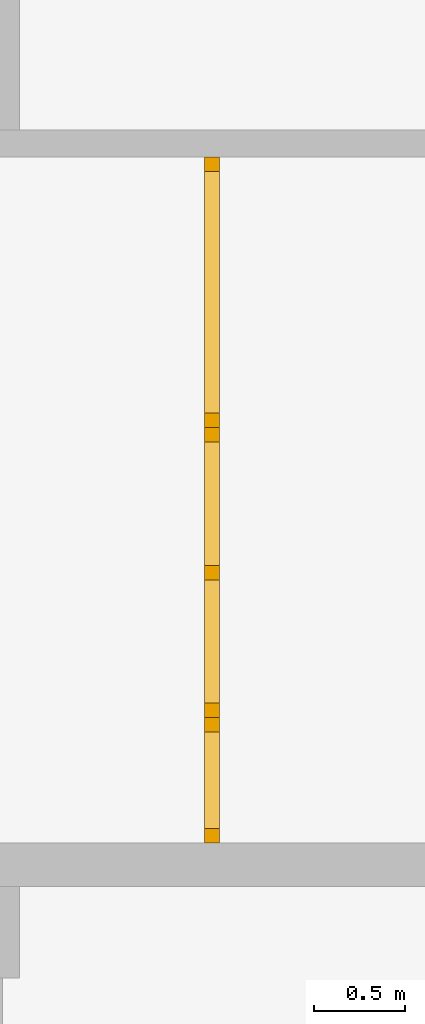
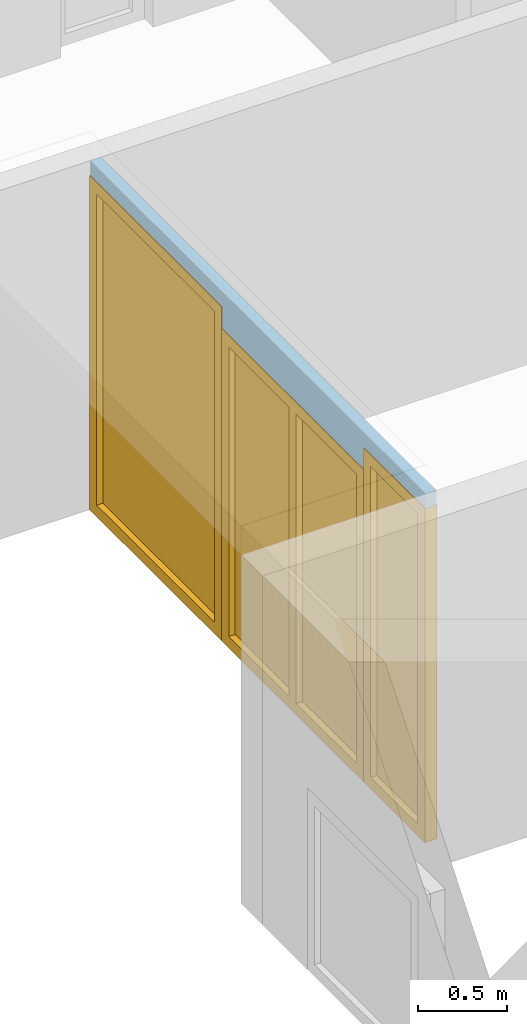
# One storey, part 5 of 8: 2 doors, 1 window, 3 openings, plus 1 element that does not belong to this part.
"""IFC2X3 building model written with IfcOpenShell, lengths in millimetres."""

from ifc_helpers import new_model, entity, si_unit, converted_unit, frame, frame_2d, origin, origin_with_axes, place, context, project, spatial, rectangle, extrude, faceted_brep, material, layer, layer_set, layer_usage, type_object, element, fill, save


model = new_model("IFC2X3")

# Units and contexts
model_context = context("Model", 3, precision=1e-05, world=origin())
plan_context = context("Plan", 3, precision=1e-05, world=origin())
ifc_project = project(units=[si_unit("LENGTHUNIT", "METRE", prefix="MILLI"), converted_unit("PLANEANGLEUNIT", "DEGREE", entity("IfcPlaneAngleMeasure", 0.0174532925199433), si_unit("PLANEANGLEUNIT", "RADIAN"), dimensions=[0, 0, 0, 0, 0, 0, 0]), si_unit("AREAUNIT", "SQUARE_METRE"), si_unit("VOLUMEUNIT", "CUBIC_METRE")], contexts=[model_context, plan_context])

# Building, storey
building_placement = place(None, origin())
building = spatial("IfcBuilding", under=ifc_project, at=building_placement, CompositionType="ELEMENT")
storey_placement = place(building_placement, frame((0.0, 0.0, 2900.0), z_axis=(0.0, 0.0, 1.0), x_axis=(1.0, 0.0, 0.0)))
storey = spatial("IfcBuildingStorey", under=building, at=storey_placement, Name="OG", CompositionType="ELEMENT", Elevation=2900.0)

# Wall, openings, doors, window
ifc_material_1 = material(Name="glas")
ifc_layer = layer(ifc_material_1, 70.0)
ifc_layer_set = layer_set([ifc_layer])
ifc_layer_usage = layer_usage(ifc_layer_set, "AXIS2", "POSITIVE", 0.0)
wall_placement = place(storey_placement, frame((22458.3517822139, 1928.4375, 0.0), z_axis=(0.0, 0.0, 1.0), x_axis=(0.0, 1.0, 0.0)))
wall = element("IfcWallStandardCase", 1, at=wall_placement, inside=storey, material=ifc_layer_usage, context=model_context, shape_type="SweptSolid", body=[
    extrude(rectangle(XDim=3780.0, YDim=70.0, at=frame_2d((1890.0, 35.0), x_axis=(1.0, 0.0))), origin_with_axes(), (0.0, 0.0, 1.0), 2400.0),
])
opening_1_placement = place(wall_placement, frame((2290.0, 0.0, 0.0), z_axis=(0.0, 1.0, 0.0), x_axis=(0.0, 0.0, 1.0)))
opening_1 = element("IfcOpeningElement", 2, at=opening_1_placement, cuts=wall, ObjectType="Opening", context=model_context, shape_type="SweptSolid", body=[
    extrude(rectangle(XDim=2300.0, YDim=1490.0, at=frame_2d((1150.0, 745.0), x_axis=(1.0, 0.0))), origin_with_axes(), (0.0, 0.0, 1.0), 70.0),
])
opening_2_placement = place(wall_placement, frame((0.0, 0.0, 0.0), z_axis=(0.0, 1.0, 0.0), x_axis=(0.0, 0.0, 1.0)))
opening_2 = element("IfcOpeningElement", 3, at=opening_2_placement, cuts=wall, ObjectType="Opening", context=model_context, shape_type="SweptSolid", body=[
    extrude(rectangle(XDim=2300.0, YDim=689.999999999996, at=frame_2d((1150.0, 344.999999999998), x_axis=(1.0, 0.0))), origin_with_axes(), (0.0, 0.0, 1.0), 70.0),
])
opening_3_placement = place(wall_placement, frame((689.999999999996, 0.0, 0.0), z_axis=(0.0, 1.0, 0.0), x_axis=(0.0, 0.0, 1.0)))
opening_3 = element("IfcOpeningElement", 4, at=opening_3_placement, cuts=wall, ObjectType="Opening", context=model_context, shape_type="SweptSolid", body=[
    extrude(rectangle(XDim=2150.0, YDim=1600.0, at=frame_2d((1075.0, 800.0), x_axis=(1.0, 0.0))), origin_with_axes(), (0.0, 0.0, 1.0), 70.0),
])
ifc_material_2 = material()
door_style_1 = type_object("IfcDoorStyle", Name="m", ConstructionType="NOTDEFINED", OperationType="USERDEFINED", ParameterTakesPrecedence=False, Sizeable=False)
door_1_placement = place(opening_1_placement, frame((0.0, 0.0, 0.0), z_axis=(1.0, 0.0, 0.0), x_axis=(0.0, 1.0, 0.0)))
door_1 = element("IfcDoor", 5, at=door_1_placement, inside=storey, type_object=door_style_1, material=ifc_material_2, Name="m", OverallHeight=2300.0, OverallWidth=1490.0, context=model_context, shape_type="Brep", body=[
    faceted_brep([(79.9999999999998, 75.0000000000016, 0.0), (79.9999999999998, 75.0000000000016, 2300.0), (-2.27373675443232e-13, 75.0000000000016, 2300.0), (-2.27373675443232e-13, 75.0000000000016, 0.0), (-2.27373675443232e-13, -4.99999999999845, 0.0), (-2.27373675443232e-13, -4.99999999999845, 2300.0), (79.9999999999998, -4.99999999999845, 2300.0), (79.9999999999998, -4.99999999999845, 0.0), (-2.27373675443232e-13, 75.0000000000016, 0.0), (-2.27373675443232e-13, -4.99999999999845, 0.0), (79.9999999999998, -4.99999999999845, 0.0), (79.9999999999998, 75.0000000000016, 0.0), (-2.27373675443232e-13, 75.0000000000016, 2300.0), (-2.27373675443232e-13, -4.99999999999845, 2300.0), (-2.27373675443232e-13, -4.99999999999845, 0.0), (-2.27373675443232e-13, 75.0000000000016, 0.0), (79.9999999999998, 75.0000000000016, 2300.0), (79.9999999999998, -4.99999999999845, 2300.0), (-2.27373675443232e-13, -4.99999999999845, 2300.0), (-2.27373675443232e-13, 75.0000000000016, 2300.0), (79.9999999999998, 75.0000000000016, 0.0), (79.9999999999998, -4.99999999999845, 0.0), (79.9999999999998, -4.99999999999845, 2300.0), (79.9999999999998, 75.0000000000016, 2300.0)], [[[0, 1, 2, 3]], [[4, 5, 6, 7]], [[8, 9, 10, 11]], [[12, 13, 14, 15]], [[16, 17, 18, 19]], [[20, 21, 22, 23]]], orient=[[False], [False], [False], [False], [False], [False]]),
    faceted_brep([(1410.0, 75.0000000000015, 2300.0), (1410.0, 75.0000000000015, 0.0), (1490.0, 75.0000000000015, 0.0), (1490.0, 75.0000000000015, 2300.0), (1490.0, -4.99999999999854, 2300.0), (1490.0, -4.99999999999854, 0.0), (1410.0, -4.99999999999854, 0.0), (1410.0, -4.99999999999854, 2300.0), (1490.0, 75.0000000000015, 2300.0), (1490.0, -4.99999999999854, 2300.0), (1410.0, -4.99999999999854, 2300.0), (1410.0, 75.0000000000015, 2300.0), (1490.0, 75.0000000000015, 0.0), (1490.0, -4.99999999999854, 0.0), (1490.0, -4.99999999999854, 2300.0), (1490.0, 75.0000000000015, 2300.0), (1410.0, 75.0000000000015, 0.0), (1410.0, -4.99999999999854, 0.0), (1490.0, -4.99999999999854, 0.0), (1490.0, 75.0000000000015, 0.0), (1410.0, 75.0000000000015, 2300.0), (1410.0, -4.99999999999854, 2300.0), (1410.0, -4.99999999999854, 0.0), (1410.0, 75.0000000000015, 0.0)], [[[0, 1, 2, 3]], [[4, 5, 6, 7]], [[8, 9, 10, 11]], [[12, 13, 14, 15]], [[16, 17, 18, 19]], [[20, 21, 22, 23]]], orient=[[False], [False], [False], [False], [False], [False]]),
    faceted_brep([(79.9999999999998, 75.0000000000015, 2220.0), (1410.0, 75.0000000000015, 2220.0), (1410.0, 75.0000000000015, 2300.0), (79.9999999999998, 75.0000000000015, 2300.0), (79.9999999999998, -4.99999999999847, 2300.0), (1410.0, -4.99999999999855, 2300.0), (1410.0, -4.99999999999855, 2220.0), (79.9999999999998, -4.99999999999847, 2220.0), (79.9999999999998, 75.0000000000015, 2300.0), (79.9999999999998, -4.99999999999847, 2300.0), (79.9999999999998, -4.99999999999847, 2220.0), (79.9999999999998, 75.0000000000015, 2220.0), (1410.0, 75.0000000000015, 2300.0), (1410.0, -4.99999999999855, 2300.0), (79.9999999999998, -4.99999999999847, 2300.0), (79.9999999999998, 75.0000000000015, 2300.0), (1410.0, 75.0000000000015, 2220.0), (1410.0, -4.99999999999855, 2220.0), (1410.0, -4.99999999999855, 2300.0), (1410.0, 75.0000000000015, 2300.0), (79.9999999999998, 75.0000000000015, 2220.0), (79.9999999999998, -4.99999999999847, 2220.0), (1410.0, -4.99999999999855, 2220.0), (1410.0, 75.0000000000015, 2220.0)], [[[0, 1, 2, 3]], [[4, 5, 6, 7]], [[8, 9, 10, 11]], [[12, 13, 14, 15]], [[16, 17, 18, 19]], [[20, 21, 22, 23]]], orient=[[False], [False], [False], [False], [False], [False]]),
    faceted_brep([(1410.0, 75.0000000000015, 80.0), (79.9999999999998, 75.0000000000015, 80.0), (79.9999999999998, 75.0000000000015, 0.0), (1410.0, 75.0000000000015, 0.0), (1410.0, -4.99999999999855, 0.0), (79.9999999999998, -4.99999999999847, 0.0), (79.9999999999998, -4.99999999999847, 80.0), (1410.0, -4.99999999999855, 80.0), (1410.0, 75.0000000000015, 0.0), (1410.0, -4.99999999999855, 0.0), (1410.0, -4.99999999999855, 80.0), (1410.0, 75.0000000000015, 80.0), (79.9999999999998, 75.0000000000015, 0.0), (79.9999999999998, -4.99999999999847, 0.0), (1410.0, -4.99999999999855, 0.0), (1410.0, 75.0000000000015, 0.0), (79.9999999999998, 75.0000000000015, 80.0), (79.9999999999998, -4.99999999999847, 80.0), (79.9999999999998, -4.99999999999847, 0.0), (79.9999999999998, 75.0000000000015, 0.0), (1410.0, 75.0000000000015, 80.0), (1410.0, -4.99999999999855, 80.0), (79.9999999999998, -4.99999999999847, 80.0), (79.9999999999998, 75.0000000000015, 80.0)], [[[0, 1, 2, 3]], [[4, 5, 6, 7]], [[8, 9, 10, 11]], [[12, 13, 14, 15]], [[16, 17, 18, 19]], [[20, 21, 22, 23]]], orient=[[False], [False], [False], [False], [False], [False]]),
    faceted_brep([(79.9999999999998, 35.0000000000015, 80.0), (1410.0, 35.0000000000015, 80.0), (1410.0, 35.0000000000015, 2220.0), (79.9999999999998, 35.0000000000015, 2220.0), (79.9999999999998, 34.0000000000015, 80.0), (79.9999999999998, 34.0000000000015, 2220.0), (1410.0, 34.0000000000015, 2220.0), (1410.0, 34.0000000000015, 80.0), (79.9999999999998, 35.0000000000015, 80.0), (79.9999999999998, 34.0000000000015, 80.0), (1410.0, 34.0000000000015, 80.0), (1410.0, 35.0000000000015, 80.0), (1410.0, 35.0000000000015, 80.0), (1410.0, 34.0000000000015, 80.0), (1410.0, 34.0000000000015, 2220.0), (1410.0, 35.0000000000015, 2220.0), (1410.0, 35.0000000000015, 2220.0), (1410.0, 34.0000000000015, 2220.0), (79.9999999999998, 34.0000000000015, 2220.0), (79.9999999999998, 35.0000000000015, 2220.0), (79.9999999999998, 35.0000000000015, 2220.0), (79.9999999999998, 34.0000000000015, 2220.0), (79.9999999999998, 34.0000000000015, 80.0), (79.9999999999998, 35.0000000000015, 80.0)], [[[0, 1, 2, 3]], [[4, 5, 6, 7]], [[8, 9, 10, 11]], [[12, 13, 14, 15]], [[16, 17, 18, 19]], [[20, 21, 22, 23]]], orient=[[False], [False], [False], [False], [False], [False]]),
])
fill(opening_1, door_1)
ifc_material_3 = material()
door_style_2 = type_object("IfcDoorStyle", Name="Verglasung 01", ConstructionType="NOTDEFINED", OperationType="USERDEFINED", ParameterTakesPrecedence=False, Sizeable=False)
door_2_placement = place(opening_2_placement, frame((0.0, 0.0, 0.0), z_axis=(1.0, 0.0, 0.0), x_axis=(0.0, 1.0, 0.0)))
door_2 = element("IfcDoor", 6, at=door_2_placement, inside=storey, type_object=door_style_2, material=ifc_material_3, Name="Verglasung 01", OverallHeight=2300.0, OverallWidth=690.0, context=model_context, shape_type="Brep", body=[
    faceted_brep([(80.0, 75.0000000000015, 0.0), (80.0, 75.0000000000015, 2300.0), (0.0, 75.0000000000015, 2300.0), (0.0, 75.0000000000015, 0.0), (0.0, -4.99999999999849, 0.0), (0.0, -4.99999999999849, 2300.0), (80.0, -4.99999999999849, 2300.0), (80.0, -4.99999999999849, 0.0), (0.0, 75.0000000000015, 0.0), (0.0, -4.99999999999849, 0.0), (80.0, -4.99999999999849, 0.0), (80.0, 75.0000000000015, 0.0), (0.0, 75.0000000000015, 2300.0), (0.0, -4.99999999999849, 2300.0), (0.0, -4.99999999999849, 0.0), (0.0, 75.0000000000015, 0.0), (80.0, 75.0000000000015, 2300.0), (80.0, -4.99999999999849, 2300.0), (0.0, -4.99999999999849, 2300.0), (0.0, 75.0000000000015, 2300.0), (80.0, 75.0000000000015, 0.0), (80.0, -4.99999999999849, 0.0), (80.0, -4.99999999999849, 2300.0), (80.0, 75.0000000000015, 2300.0)], [[[0, 1, 2, 3]], [[4, 5, 6, 7]], [[8, 9, 10, 11]], [[12, 13, 14, 15]], [[16, 17, 18, 19]], [[20, 21, 22, 23]]], orient=[[False], [False], [False], [False], [False], [False]]),
    faceted_brep([(609.999999999996, 75.0000000000015, 2300.0), (609.999999999996, 75.0000000000015, 0.0), (689.999999999996, 75.0000000000015, 0.0), (689.999999999996, 75.0000000000015, 2300.0), (689.999999999996, -4.99999999999854, 2300.0), (689.999999999996, -4.99999999999854, 0.0), (609.999999999996, -4.99999999999854, 0.0), (609.999999999996, -4.99999999999854, 2300.0), (689.999999999996, 75.0000000000015, 2300.0), (689.999999999996, -4.99999999999854, 2300.0), (609.999999999996, -4.99999999999854, 2300.0), (609.999999999996, 75.0000000000015, 2300.0), (689.999999999996, 75.0000000000015, 0.0), (689.999999999996, -4.99999999999854, 0.0), (689.999999999996, -4.99999999999854, 2300.0), (689.999999999996, 75.0000000000015, 2300.0), (609.999999999996, 75.0000000000015, 0.0), (609.999999999996, -4.99999999999854, 0.0), (689.999999999996, -4.99999999999854, 0.0), (689.999999999996, 75.0000000000015, 0.0), (609.999999999996, 75.0000000000015, 2300.0), (609.999999999996, -4.99999999999854, 2300.0), (609.999999999996, -4.99999999999854, 0.0), (609.999999999996, 75.0000000000015, 0.0)], [[[0, 1, 2, 3]], [[4, 5, 6, 7]], [[8, 9, 10, 11]], [[12, 13, 14, 15]], [[16, 17, 18, 19]], [[20, 21, 22, 23]]], orient=[[False], [False], [False], [False], [False], [False]]),
    faceted_brep([(80.0, 75.0000000000015, 2220.0), (609.999999999996, 75.0000000000015, 2220.0), (609.999999999996, 75.0000000000015, 2300.0), (80.0, 75.0000000000015, 2300.0), (80.0, -4.99999999999851, 2300.0), (609.999999999996, -4.99999999999855, 2300.0), (609.999999999996, -4.99999999999855, 2220.0), (80.0, -4.99999999999851, 2220.0), (80.0, 75.0000000000015, 2300.0), (80.0, -4.99999999999851, 2300.0), (80.0, -4.99999999999851, 2220.0), (80.0, 75.0000000000015, 2220.0), (609.999999999996, 75.0000000000015, 2300.0), (609.999999999996, -4.99999999999855, 2300.0), (80.0, -4.99999999999851, 2300.0), (80.0, 75.0000000000015, 2300.0), (609.999999999996, 75.0000000000015, 2220.0), (609.999999999996, -4.99999999999855, 2220.0), (609.999999999996, -4.99999999999855, 2300.0), (609.999999999996, 75.0000000000015, 2300.0), (80.0, 75.0000000000015, 2220.0), (80.0, -4.99999999999851, 2220.0), (609.999999999996, -4.99999999999855, 2220.0), (609.999999999996, 75.0000000000015, 2220.0)], [[[0, 1, 2, 3]], [[4, 5, 6, 7]], [[8, 9, 10, 11]], [[12, 13, 14, 15]], [[16, 17, 18, 19]], [[20, 21, 22, 23]]], orient=[[False], [False], [False], [False], [False], [False]]),
    faceted_brep([(609.999999999996, 75.0000000000015, 80.0), (80.0, 75.0000000000015, 80.0), (80.0, 75.0000000000015, 0.0), (609.999999999996, 75.0000000000015, 0.0), (609.999999999996, -4.99999999999855, 0.0), (80.0, -4.99999999999851, 0.0), (80.0, -4.99999999999851, 80.0), (609.999999999996, -4.99999999999855, 80.0), (609.999999999996, 75.0000000000015, 0.0), (609.999999999996, -4.99999999999855, 0.0), (609.999999999996, -4.99999999999855, 80.0), (609.999999999996, 75.0000000000015, 80.0), (80.0, 75.0000000000015, 0.0), (80.0, -4.99999999999851, 0.0), (609.999999999996, -4.99999999999855, 0.0), (609.999999999996, 75.0000000000015, 0.0), (80.0, 75.0000000000015, 80.0), (80.0, -4.99999999999851, 80.0), (80.0, -4.99999999999851, 0.0), (80.0, 75.0000000000015, 0.0), (609.999999999996, 75.0000000000015, 80.0), (609.999999999996, -4.99999999999855, 80.0), (80.0, -4.99999999999851, 80.0), (80.0, 75.0000000000015, 80.0)], [[[0, 1, 2, 3]], [[4, 5, 6, 7]], [[8, 9, 10, 11]], [[12, 13, 14, 15]], [[16, 17, 18, 19]], [[20, 21, 22, 23]]], orient=[[False], [False], [False], [False], [False], [False]]),
    faceted_brep([(80.0, 35.0000000000015, 80.0), (609.999999999996, 35.0000000000015, 80.0), (609.999999999996, 35.0000000000015, 2220.0), (80.0, 35.0000000000015, 2220.0), (80.0, 34.0000000000015, 80.0), (80.0, 34.0000000000015, 2220.0), (609.999999999996, 34.0000000000015, 2220.0), (609.999999999996, 34.0000000000015, 80.0), (80.0, 35.0000000000015, 80.0), (80.0, 34.0000000000015, 80.0), (609.999999999996, 34.0000000000015, 80.0), (609.999999999996, 35.0000000000015, 80.0), (609.999999999996, 35.0000000000015, 80.0), (609.999999999996, 34.0000000000015, 80.0), (609.999999999996, 34.0000000000015, 2220.0), (609.999999999996, 35.0000000000015, 2220.0), (609.999999999996, 35.0000000000015, 2220.0), (609.999999999996, 34.0000000000015, 2220.0), (80.0, 34.0000000000015, 2220.0), (80.0, 35.0000000000015, 2220.0), (80.0, 35.0000000000015, 2220.0), (80.0, 34.0000000000015, 2220.0), (80.0, 34.0000000000015, 80.0), (80.0, 35.0000000000015, 80.0)], [[[0, 1, 2, 3]], [[4, 5, 6, 7]], [[8, 9, 10, 11]], [[12, 13, 14, 15]], [[16, 17, 18, 19]], [[20, 21, 22, 23]]], orient=[[False], [False], [False], [False], [False], [False]]),
])
fill(opening_2, door_2)
ifc_material_4 = material()
window_placement = place(opening_3_placement, frame((0.0, 0.0, 0.0), z_axis=(1.0, 0.0, 0.0), x_axis=(0.0, 1.0, 0.0)))
window = element("IfcWindow", 7, at=window_placement, inside=storey, material=ifc_material_4, Name="m", OverallHeight=2150.0, OverallWidth=1600.0, context=model_context, shape_type="Brep", body=[
    faceted_brep([(80.0000000000005, 75.0000000000016, 0.0), (80.0000000000005, 75.0000000000016, 2150.0), (4.54747350886464e-13, 75.0000000000016, 2150.0), (4.54747350886464e-13, 75.0000000000016, 0.0), (4.54747350886464e-13, -4.99999999999844, 0.0), (4.54747350886464e-13, -4.99999999999844, 2150.0), (80.0000000000005, -4.99999999999844, 2150.0), (80.0000000000005, -4.99999999999844, 0.0), (4.54747350886464e-13, 75.0000000000016, 0.0), (4.54747350886464e-13, -4.99999999999844, 0.0), (80.0000000000005, -4.99999999999844, 0.0), (80.0000000000005, 75.0000000000016, 0.0), (4.54747350886464e-13, 75.0000000000016, 2150.0), (4.54747350886464e-13, -4.99999999999844, 2150.0), (4.54747350886464e-13, -4.99999999999844, 0.0), (4.54747350886464e-13, 75.0000000000016, 0.0), (80.0000000000005, 75.0000000000016, 2150.0), (80.0000000000005, -4.99999999999844, 2150.0), (4.54747350886464e-13, -4.99999999999844, 2150.0), (4.54747350886464e-13, 75.0000000000016, 2150.0), (80.0000000000005, 75.0000000000016, 0.0), (80.0000000000005, -4.99999999999844, 0.0), (80.0000000000005, -4.99999999999844, 2150.0), (80.0000000000005, 75.0000000000016, 2150.0)], [[[0, 1, 2, 3]], [[4, 5, 6, 7]], [[8, 9, 10, 11]], [[12, 13, 14, 15]], [[16, 17, 18, 19]], [[20, 21, 22, 23]]], orient=[[False], [False], [False], [False], [False], [False]]),
    faceted_brep([(1520.0, 75.0000000000015, 2150.0), (1520.0, 75.0000000000015, 0.0), (1600.0, 75.0000000000015, 0.0), (1600.0, 75.0000000000015, 2150.0), (1600.0, -4.99999999999854, 2150.0), (1600.0, -4.99999999999854, 0.0), (1520.0, -4.99999999999854, 0.0), (1520.0, -4.99999999999854, 2150.0), (1600.0, 75.0000000000015, 2150.0), (1600.0, -4.99999999999854, 2150.0), (1520.0, -4.99999999999854, 2150.0), (1520.0, 75.0000000000015, 2150.0), (1600.0, 75.0000000000015, 0.0), (1600.0, -4.99999999999854, 0.0), (1600.0, -4.99999999999854, 2150.0), (1600.0, 75.0000000000015, 2150.0), (1520.0, 75.0000000000015, 0.0), (1520.0, -4.99999999999854, 0.0), (1600.0, -4.99999999999854, 0.0), (1600.0, 75.0000000000015, 0.0), (1520.0, 75.0000000000015, 2150.0), (1520.0, -4.99999999999854, 2150.0), (1520.0, -4.99999999999854, 0.0), (1520.0, 75.0000000000015, 0.0)], [[[0, 1, 2, 3]], [[4, 5, 6, 7]], [[8, 9, 10, 11]], [[12, 13, 14, 15]], [[16, 17, 18, 19]], [[20, 21, 22, 23]]], orient=[[False], [False], [False], [False], [False], [False]]),
    faceted_brep([(80.0000000000005, 75.0000000000015, 2070.0), (1520.0, 75.0000000000015, 2070.0), (1520.0, 75.0000000000015, 2150.0), (80.0000000000005, 75.0000000000015, 2150.0), (80.0000000000005, -4.99999999999845, 2150.0), (1520.0, -4.99999999999855, 2150.0), (1520.0, -4.99999999999855, 2070.0), (80.0000000000005, -4.99999999999845, 2070.0), (80.0000000000005, 75.0000000000015, 2150.0), (80.0000000000005, -4.99999999999845, 2150.0), (80.0000000000005, -4.99999999999845, 2070.0), (80.0000000000005, 75.0000000000015, 2070.0), (1520.0, 75.0000000000015, 2150.0), (1520.0, -4.99999999999855, 2150.0), (80.0000000000005, -4.99999999999845, 2150.0), (80.0000000000005, 75.0000000000015, 2150.0), (1520.0, 75.0000000000015, 2070.0), (1520.0, -4.99999999999855, 2070.0), (1520.0, -4.99999999999855, 2150.0), (1520.0, 75.0000000000015, 2150.0), (80.0000000000005, 75.0000000000015, 2070.0), (80.0000000000005, -4.99999999999845, 2070.0), (1520.0, -4.99999999999855, 2070.0), (1520.0, 75.0000000000015, 2070.0)], [[[0, 1, 2, 3]], [[4, 5, 6, 7]], [[8, 9, 10, 11]], [[12, 13, 14, 15]], [[16, 17, 18, 19]], [[20, 21, 22, 23]]], orient=[[False], [False], [False], [False], [False], [False]]),
    faceted_brep([(1520.0, 75.0000000000015, 80.0), (80.0000000000005, 75.0000000000015, 80.0), (80.0000000000005, 75.0000000000015, 0.0), (1520.0, 75.0000000000015, 0.0), (1520.0, -4.99999999999855, 0.0), (80.0000000000005, -4.99999999999845, 0.0), (80.0000000000005, -4.99999999999845, 80.0), (1520.0, -4.99999999999855, 80.0), (1520.0, 75.0000000000015, 0.0), (1520.0, -4.99999999999855, 0.0), (1520.0, -4.99999999999855, 80.0), (1520.0, 75.0000000000015, 80.0), (80.0000000000005, 75.0000000000015, 0.0), (80.0000000000005, -4.99999999999845, 0.0), (1520.0, -4.99999999999855, 0.0), (1520.0, 75.0000000000015, 0.0), (80.0000000000005, 75.0000000000015, 80.0), (80.0000000000005, -4.99999999999845, 80.0), (80.0000000000005, -4.99999999999845, 0.0), (80.0000000000005, 75.0000000000015, 0.0), (1520.0, 75.0000000000015, 80.0), (1520.0, -4.99999999999855, 80.0), (80.0000000000005, -4.99999999999845, 80.0), (80.0000000000005, 75.0000000000015, 80.0)], [[[0, 1, 2, 3]], [[4, 5, 6, 7]], [[8, 9, 10, 11]], [[12, 13, 14, 15]], [[16, 17, 18, 19]], [[20, 21, 22, 23]]], orient=[[False], [False], [False], [False], [False], [False]]),
    faceted_brep([(840.0, 75.0000000000015, 80.0), (840.0, 75.0000000000015, 2070.0), (760.0, 75.0000000000015, 2070.0), (760.0, 75.0000000000015, 80.0), (760.0, -4.99999999999849, 80.0), (760.0, -4.99999999999849, 2070.0), (840.0, -4.99999999999851, 2070.0), (840.0, -4.99999999999851, 80.0), (760.0, 75.0000000000015, 80.0), (760.0, -4.99999999999849, 80.0), (840.0, -4.99999999999851, 80.0), (840.0, 75.0000000000015, 80.0), (760.0, 75.0000000000015, 2070.0), (760.0, -4.99999999999849, 2070.0), (760.0, -4.99999999999849, 80.0), (760.0, 75.0000000000015, 80.0), (840.0, 75.0000000000015, 2070.0), (840.0, -4.99999999999851, 2070.0), (760.0, -4.99999999999849, 2070.0), (760.0, 75.0000000000015, 2070.0), (840.0, 75.0000000000015, 80.0), (840.0, -4.99999999999851, 80.0), (840.0, -4.99999999999851, 2070.0), (840.0, 75.0000000000015, 2070.0)], [[[0, 1, 2, 3]], [[4, 5, 6, 7]], [[8, 9, 10, 11]], [[12, 13, 14, 15]], [[16, 17, 18, 19]], [[20, 21, 22, 23]]], orient=[[False], [False], [False], [False], [False], [False]]),
    faceted_brep([(1520.0, 35.0000000000015, 2070.0), (840.0, 35.0000000000015, 2070.0), (840.0, 35.0000000000015, 80.0), (1520.0, 35.0000000000015, 80.0), (1520.0, 34.0000000000015, 2070.0), (1520.0, 34.0000000000015, 80.0), (840.0, 34.0000000000015, 80.0), (840.0, 34.0000000000015, 2070.0), (1520.0, 35.0000000000015, 2070.0), (1520.0, 34.0000000000015, 2070.0), (840.0, 34.0000000000015, 2070.0), (840.0, 35.0000000000015, 2070.0), (840.0, 35.0000000000015, 2070.0), (840.0, 34.0000000000015, 2070.0), (840.0, 34.0000000000015, 80.0), (840.0, 35.0000000000015, 80.0), (840.0, 35.0000000000015, 80.0), (840.0, 34.0000000000015, 80.0), (1520.0, 34.0000000000015, 80.0), (1520.0, 35.0000000000015, 80.0), (1520.0, 35.0000000000015, 80.0), (1520.0, 34.0000000000015, 80.0), (1520.0, 34.0000000000015, 2070.0), (1520.0, 35.0000000000015, 2070.0)], [[[0, 1, 2, 3]], [[4, 5, 6, 7]], [[8, 9, 10, 11]], [[12, 13, 14, 15]], [[16, 17, 18, 19]], [[20, 21, 22, 23]]], orient=[[False], [False], [False], [False], [False], [False]]),
    faceted_brep([(80.0000000000005, 35.0000000000015, 80.0), (760.0, 35.0000000000015, 80.0), (760.0, 35.0000000000015, 2070.0), (80.0000000000005, 35.0000000000015, 2070.0), (80.0000000000005, 34.0000000000015, 80.0), (80.0000000000005, 34.0000000000015, 2070.0), (760.0, 34.0000000000015, 2070.0), (760.0, 34.0000000000015, 80.0), (80.0000000000005, 35.0000000000015, 80.0), (80.0000000000005, 34.0000000000015, 80.0), (760.0, 34.0000000000015, 80.0), (760.0, 35.0000000000015, 80.0), (760.0, 35.0000000000015, 80.0), (760.0, 34.0000000000015, 80.0), (760.0, 34.0000000000015, 2070.0), (760.0, 35.0000000000015, 2070.0), (760.0, 35.0000000000015, 2070.0), (760.0, 34.0000000000015, 2070.0), (80.0000000000005, 34.0000000000015, 2070.0), (80.0000000000005, 35.0000000000015, 2070.0), (80.0000000000005, 35.0000000000015, 2070.0), (80.0000000000005, 34.0000000000015, 2070.0), (80.0000000000005, 34.0000000000015, 80.0), (80.0000000000005, 35.0000000000015, 80.0)], [[[0, 1, 2, 3]], [[4, 5, 6, 7]], [[8, 9, 10, 11]], [[12, 13, 14, 15]], [[16, 17, 18, 19]], [[20, 21, 22, 23]]], orient=[[False], [False], [False], [False], [False], [False]]),
])
fill(opening_3, window)

save(model, "model.ifc")
